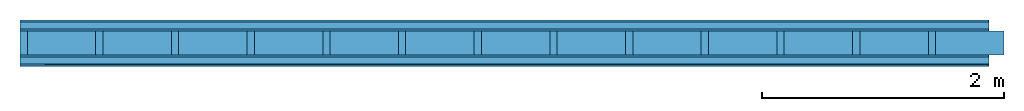
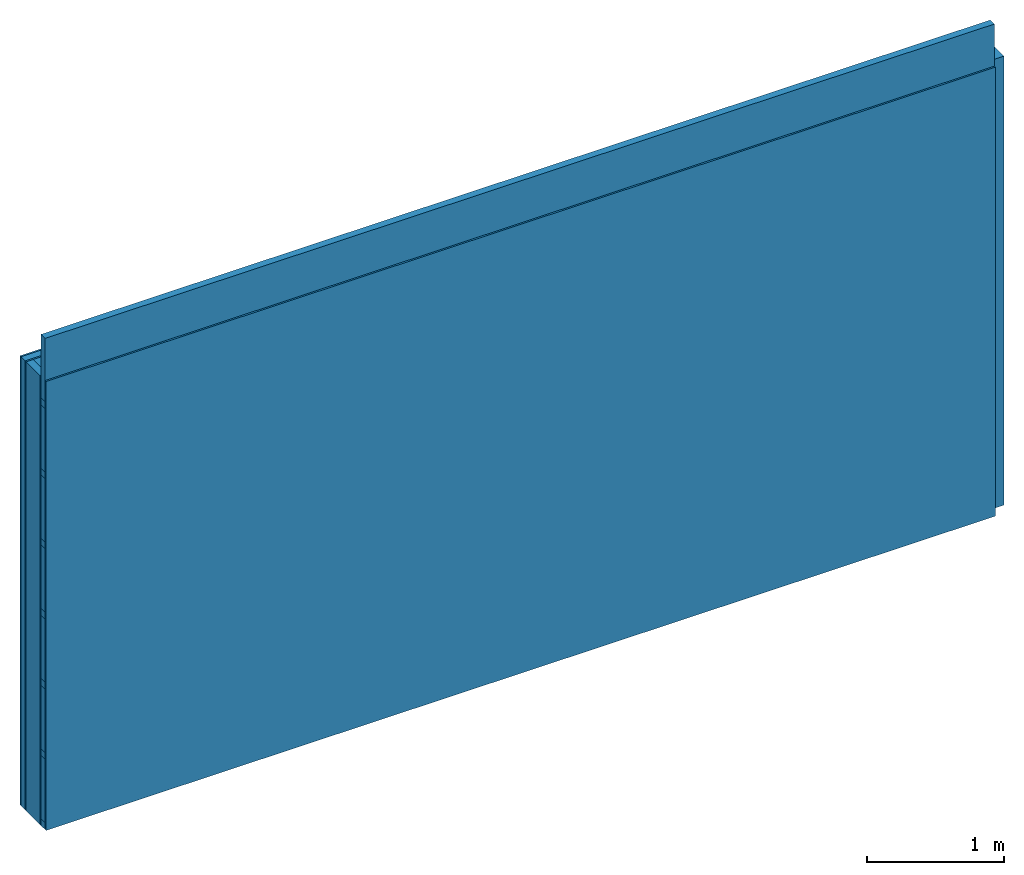
# One storey: 5 plates, 4 members, 1 element without a shape of its own.
"""IFC4 building model written with IfcOpenShell, lengths in metres."""

from ifc_helpers import new_model, si_unit, derived_unit, direction, frame, frame_2d, origin, origin_with_axes, place, context, project, spatial, rectangle, extrude, material, layer, layer_set, type_object, element, aggregate, save


model = new_model("IFC4")

# Units and contexts
plan_context = context("Plan", 3, precision=1e-05, world=origin(), true_north=direction((0.0, 1.0)))
model_context = context("Model", 3, precision=1e-05, world=origin(), true_north=direction((0.0, 1.0)))
ifc_project = project(units=[si_unit("LENGTHUNIT", "METRE"), derived_unit("SOUNDPRESSUREUNIT", [(si_unit("PRESSUREUNIT", "PASCAL", prefix="MICRO"), 0)]), si_unit("ENERGYUNIT", "JOULE", prefix="MEGA"), si_unit("MASSUNIT", "GRAM", prefix="KILO"), derived_unit("THERMALTRANSMITTANCEUNIT", [(si_unit("POWERUNIT", "WATT"), 1), (si_unit("AREAUNIT", "SQUARE_METRE"), -1), (si_unit("THERMODYNAMICTEMPERATUREUNIT", "KELVIN"), -1)]), derived_unit("AREADENSITYUNIT", [(si_unit("MASSUNIT", "GRAM", prefix="KILO"), 1), (si_unit("AREAUNIT", "SQUARE_METRE"), -1)]), derived_unit("USERDEFINED", [(si_unit("ENERGYUNIT", "JOULE", prefix="MEGA"), 1), (si_unit("AREAUNIT", "SQUARE_METRE"), -1)])], contexts=[plan_context, model_context])

# Site, building, storey
site = spatial("IfcSite", under=ifc_project)
building_placement = place(None, origin())
building = spatial("IfcBuilding", under=site, at=building_placement)
storey_placement = place(building_placement, origin())
storey = spatial("IfcBuildingStorey", under=building, at=storey_placement)

# Wall, members, plates
ifc_material_1 = material(Category="04.011")
ifc_layer_1 = layer(ifc_material_1, 0.015, Name="Surface 1")
ifc_material_2 = material(Category="10.008")
ifc_layer_2 = layer(ifc_material_2, 0.06, Name="outside 2nd layer")
ifc_material_3 = material(Category="03.007")
ifc_layer_3 = layer(ifc_material_3, 0.015, Name="outside 1st layer")
ifc_material_4 = material(Name="of the art")
ifc_layer_4 = layer(ifc_material_4, 0.0, Name="Bond")
ifc_layer_5 = layer(None, 0.2, Name="Support")
ifc_layer_6 = layer(ifc_material_4, 0.0, Name="Bond")
ifc_layer_7 = layer(ifc_material_3, 0.015, Name="1st layer")
ifc_layer_8 = layer(None, 0.06, Name="Battens / profiles")
ifc_layer_9 = layer(ifc_material_3, 0.015, Name="Covering 1st layer")
ifc_material_5 = material(Name="Glued joints")
ifc_layer_10 = layer(ifc_material_5, 0.0, Name="Surface")
ifc_layer_set = layer_set([ifc_layer_1, ifc_layer_2, ifc_layer_3, ifc_layer_4, ifc_layer_5, ifc_layer_6, ifc_layer_7, ifc_layer_8, ifc_layer_9, ifc_layer_10])
wall_type = type_object("IfcWallType", Name="D0601", PredefinedType="NOTDEFINED", material=ifc_layer_set)
wall_placement = place(None, frame((0.0, 0.0, 0.0), z_axis=(0.0, -1.0, 0.0), x_axis=(1.0, 0.0, 0.0)))
wall = element("IfcWall", 1, at=wall_placement, inside=storey, type_object=wall_type, material=ifc_layer_set, Name="Wall #1")
ifc_material_6 = material()
member_1_placement = place(wall_placement, origin())
member_1 = element("IfcMember", 2, at=member_1_placement, material=ifc_material_6, Name="Support", context=plan_context, shape_type="SweptSolid", body=[
    extrude(rectangle(XDim=0.06, YDim=0.2, at=frame_2d((0.03, 0.1), x_axis=(1.0, 0.0))), frame((0.0, 4.0, 0.09), z_axis=(0.0, -1.0, 0.0), x_axis=(1.0, 0.0, 0.0)), (0.0, 0.0, 1.0), 4.0),
    extrude(rectangle(XDim=0.06, YDim=0.2, at=frame_2d((0.03, 0.1), x_axis=(1.0, 0.0))), frame((0.625, 4.0, 0.09), z_axis=(0.0, -1.0, 0.0), x_axis=(1.0, 0.0, 0.0)), (0.0, 0.0, 1.0), 4.0),
    extrude(rectangle(XDim=0.06, YDim=0.2, at=frame_2d((0.03, 0.1), x_axis=(1.0, 0.0))), frame((1.25, 4.0, 0.09), z_axis=(0.0, -1.0, 0.0), x_axis=(1.0, 0.0, 0.0)), (0.0, 0.0, 1.0), 4.0),
    extrude(rectangle(XDim=0.06, YDim=0.2, at=frame_2d((0.03, 0.1), x_axis=(1.0, 0.0))), frame((1.875, 4.0, 0.09), z_axis=(0.0, -1.0, 0.0), x_axis=(1.0, 0.0, 0.0)), (0.0, 0.0, 1.0), 4.0),
    extrude(rectangle(XDim=0.06, YDim=0.2, at=frame_2d((0.03, 0.1), x_axis=(1.0, 0.0))), frame((2.5, 4.0, 0.09), z_axis=(0.0, -1.0, 0.0), x_axis=(1.0, 0.0, 0.0)), (0.0, 0.0, 1.0), 4.0),
    extrude(rectangle(XDim=0.06, YDim=0.2, at=frame_2d((0.03, 0.1), x_axis=(1.0, 0.0))), frame((3.125, 4.0, 0.09), z_axis=(0.0, -1.0, 0.0), x_axis=(1.0, 0.0, 0.0)), (0.0, 0.0, 1.0), 4.0),
    extrude(rectangle(XDim=0.06, YDim=0.2, at=frame_2d((0.03, 0.1), x_axis=(1.0, 0.0))), frame((3.75, 4.0, 0.09), z_axis=(0.0, -1.0, 0.0), x_axis=(1.0, 0.0, 0.0)), (0.0, 0.0, 1.0), 4.0),
    extrude(rectangle(XDim=0.06, YDim=0.2, at=frame_2d((0.03, 0.1), x_axis=(1.0, 0.0))), frame((4.375, 4.0, 0.09), z_axis=(0.0, -1.0, 0.0), x_axis=(1.0, 0.0, 0.0)), (0.0, 0.0, 1.0), 4.0),
    extrude(rectangle(XDim=0.06, YDim=0.2, at=frame_2d((0.03, 0.1), x_axis=(1.0, 0.0))), frame((5.0, 4.0, 0.09), z_axis=(0.0, -1.0, 0.0), x_axis=(1.0, 0.0, 0.0)), (0.0, 0.0, 1.0), 4.0),
    extrude(rectangle(XDim=0.06, YDim=0.2, at=frame_2d((0.03, 0.1), x_axis=(1.0, 0.0))), frame((5.625, 4.0, 0.09), z_axis=(0.0, -1.0, 0.0), x_axis=(1.0, 0.0, 0.0)), (0.0, 0.0, 1.0), 4.0),
    extrude(rectangle(XDim=0.06, YDim=0.2, at=frame_2d((0.03, 0.1), x_axis=(1.0, 0.0))), frame((6.25, 4.0, 0.09), z_axis=(0.0, -1.0, 0.0), x_axis=(1.0, 0.0, 0.0)), (0.0, 0.0, 1.0), 4.0),
    extrude(rectangle(XDim=0.06, YDim=0.2, at=frame_2d((0.03, 0.1), x_axis=(1.0, 0.0))), frame((6.875, 4.0, 0.09), z_axis=(0.0, -1.0, 0.0), x_axis=(1.0, 0.0, 0.0)), (0.0, 0.0, 1.0), 4.0),
    extrude(rectangle(XDim=0.06, YDim=0.2, at=frame_2d((0.03, 0.1), x_axis=(1.0, 0.0))), frame((7.5, 4.0, 0.09), z_axis=(0.0, -1.0, 0.0), x_axis=(1.0, 0.0, 0.0)), (0.0, 0.0, 1.0), 4.0),
])
ifc_material_7 = material()
member_2_placement = place(wall_placement, origin())
member_2 = element("IfcMember", 3, at=member_2_placement, material=ifc_material_7, Name="Cavity", context=plan_context, shape_type="SweptSolid", body=[
    extrude(rectangle(XDim=0.565, YDim=0.2, at=frame_2d((0.2825, 0.1), x_axis=(1.0, 0.0))), frame((0.06, 4.0, 0.09), z_axis=(0.0, -1.0, 0.0), x_axis=(1.0, 0.0, 0.0)), (0.0, 0.0, 1.0), 4.0),
    extrude(rectangle(XDim=0.565, YDim=0.2, at=frame_2d((0.2825, 0.1), x_axis=(1.0, 0.0))), frame((0.685, 4.0, 0.09), z_axis=(0.0, -1.0, 0.0), x_axis=(1.0, 0.0, 0.0)), (0.0, 0.0, 1.0), 4.0),
    extrude(rectangle(XDim=0.565, YDim=0.2, at=frame_2d((0.2825, 0.1), x_axis=(1.0, 0.0))), frame((1.31, 4.0, 0.09), z_axis=(0.0, -1.0, 0.0), x_axis=(1.0, 0.0, 0.0)), (0.0, 0.0, 1.0), 4.0),
    extrude(rectangle(XDim=0.565, YDim=0.2, at=frame_2d((0.2825, 0.1), x_axis=(1.0, 0.0))), frame((1.935, 4.0, 0.09), z_axis=(0.0, -1.0, 0.0), x_axis=(1.0, 0.0, 0.0)), (0.0, 0.0, 1.0), 4.0),
    extrude(rectangle(XDim=0.565, YDim=0.2, at=frame_2d((0.2825, 0.1), x_axis=(1.0, 0.0))), frame((2.56, 4.0, 0.09), z_axis=(0.0, -1.0, 0.0), x_axis=(1.0, 0.0, 0.0)), (0.0, 0.0, 1.0), 4.0),
    extrude(rectangle(XDim=0.565, YDim=0.2, at=frame_2d((0.2825, 0.1), x_axis=(1.0, 0.0))), frame((3.185, 4.0, 0.09), z_axis=(0.0, -1.0, 0.0), x_axis=(1.0, 0.0, 0.0)), (0.0, 0.0, 1.0), 4.0),
    extrude(rectangle(XDim=0.565, YDim=0.2, at=frame_2d((0.2825, 0.1), x_axis=(1.0, 0.0))), frame((3.81, 4.0, 0.09), z_axis=(0.0, -1.0, 0.0), x_axis=(1.0, 0.0, 0.0)), (0.0, 0.0, 1.0), 4.0),
    extrude(rectangle(XDim=0.565, YDim=0.2, at=frame_2d((0.2825, 0.1), x_axis=(1.0, 0.0))), frame((4.435, 4.0, 0.09), z_axis=(0.0, -1.0, 0.0), x_axis=(1.0, 0.0, 0.0)), (0.0, 0.0, 1.0), 4.0),
    extrude(rectangle(XDim=0.565, YDim=0.2, at=frame_2d((0.2825, 0.1), x_axis=(1.0, 0.0))), frame((5.06, 4.0, 0.09), z_axis=(0.0, -1.0, 0.0), x_axis=(1.0, 0.0, 0.0)), (0.0, 0.0, 1.0), 4.0),
    extrude(rectangle(XDim=0.565, YDim=0.2, at=frame_2d((0.2825, 0.1), x_axis=(1.0, 0.0))), frame((5.685, 4.0, 0.09), z_axis=(0.0, -1.0, 0.0), x_axis=(1.0, 0.0, 0.0)), (0.0, 0.0, 1.0), 4.0),
    extrude(rectangle(XDim=0.565, YDim=0.2, at=frame_2d((0.2825, 0.1), x_axis=(1.0, 0.0))), frame((6.31, 4.0, 0.09), z_axis=(0.0, -1.0, 0.0), x_axis=(1.0, 0.0, 0.0)), (0.0, 0.0, 1.0), 4.0),
    extrude(rectangle(XDim=0.565, YDim=0.2, at=frame_2d((0.2825, 0.1), x_axis=(1.0, 0.0))), frame((6.935, 4.0, 0.09), z_axis=(0.0, -1.0, 0.0), x_axis=(1.0, 0.0, 0.0)), (0.0, 0.0, 1.0), 4.0),
    extrude(rectangle(XDim=0.565, YDim=0.2, at=frame_2d((0.2825, 0.1), x_axis=(1.0, 0.0))), frame((7.56, 4.0, 0.09), z_axis=(0.0, -1.0, 0.0), x_axis=(1.0, 0.0, 0.0)), (0.0, 0.0, 1.0), 4.0),
])
ifc_material_8 = material()
member_3_placement = place(wall_placement, origin())
member_3 = element("IfcMember", 4, at=member_3_placement, material=ifc_material_8, Name="Battens / profiles", context=plan_context, shape_type="SweptSolid", body=[
    extrude(rectangle(XDim=0.06, YDim=0.06, at=frame_2d((0.03, 0.03), x_axis=(1.0, 0.0))), frame((0.0, 0.0, 0.305), z_axis=(1.0, 0.0, 0.0), x_axis=(0.0, 1.0, 0.0)), (0.0, 0.0, 1.0), 8.0),
    extrude(rectangle(XDim=0.06, YDim=0.06, at=frame_2d((0.03, 0.03), x_axis=(1.0, 0.0))), frame((0.0, 0.625, 0.305), z_axis=(1.0, 0.0, 0.0), x_axis=(0.0, 1.0, 0.0)), (0.0, 0.0, 1.0), 8.0),
    extrude(rectangle(XDim=0.06, YDim=0.06, at=frame_2d((0.03, 0.03), x_axis=(1.0, 0.0))), frame((0.0, 1.25, 0.305), z_axis=(1.0, 0.0, 0.0), x_axis=(0.0, 1.0, 0.0)), (0.0, 0.0, 1.0), 8.0),
    extrude(rectangle(XDim=0.06, YDim=0.06, at=frame_2d((0.03, 0.03), x_axis=(1.0, 0.0))), frame((0.0, 1.875, 0.305), z_axis=(1.0, 0.0, 0.0), x_axis=(0.0, 1.0, 0.0)), (0.0, 0.0, 1.0), 8.0),
    extrude(rectangle(XDim=0.06, YDim=0.06, at=frame_2d((0.03, 0.03), x_axis=(1.0, 0.0))), frame((0.0, 2.5, 0.305), z_axis=(1.0, 0.0, 0.0), x_axis=(0.0, 1.0, 0.0)), (0.0, 0.0, 1.0), 8.0),
    extrude(rectangle(XDim=0.06, YDim=0.06, at=frame_2d((0.03, 0.03), x_axis=(1.0, 0.0))), frame((0.0, 3.125, 0.305), z_axis=(1.0, 0.0, 0.0), x_axis=(0.0, 1.0, 0.0)), (0.0, 0.0, 1.0), 8.0),
    extrude(rectangle(XDim=0.06, YDim=0.06, at=frame_2d((0.03, 0.03), x_axis=(1.0, 0.0))), frame((0.0, 3.75, 0.305), z_axis=(1.0, 0.0, 0.0), x_axis=(0.0, 1.0, 0.0)), (0.0, 0.0, 1.0), 8.0),
])
member_4_placement = place(wall_placement, origin())
member_4 = element("IfcMember", 5, at=member_4_placement, material=ifc_material_7, Name="Cavity", context=plan_context, shape_type="SweptSolid", body=[
    extrude(rectangle(XDim=0.565, YDim=0.06, at=frame_2d((0.2825, 0.03), x_axis=(1.0, 0.0))), frame((0.0, 0.06, 0.305), z_axis=(1.0, 0.0, 0.0), x_axis=(0.0, 1.0, 0.0)), (0.0, 0.0, 1.0), 8.0),
    extrude(rectangle(XDim=0.565, YDim=0.06, at=frame_2d((0.2825, 0.03), x_axis=(1.0, 0.0))), frame((0.0, 0.685, 0.305), z_axis=(1.0, 0.0, 0.0), x_axis=(0.0, 1.0, 0.0)), (0.0, 0.0, 1.0), 8.0),
    extrude(rectangle(XDim=0.565, YDim=0.06, at=frame_2d((0.2825, 0.03), x_axis=(1.0, 0.0))), frame((0.0, 1.31, 0.305), z_axis=(1.0, 0.0, 0.0), x_axis=(0.0, 1.0, 0.0)), (0.0, 0.0, 1.0), 8.0),
    extrude(rectangle(XDim=0.565, YDim=0.06, at=frame_2d((0.2825, 0.03), x_axis=(1.0, 0.0))), frame((0.0, 1.935, 0.305), z_axis=(1.0, 0.0, 0.0), x_axis=(0.0, 1.0, 0.0)), (0.0, 0.0, 1.0), 8.0),
    extrude(rectangle(XDim=0.565, YDim=0.06, at=frame_2d((0.2825, 0.03), x_axis=(1.0, 0.0))), frame((0.0, 2.56, 0.305), z_axis=(1.0, 0.0, 0.0), x_axis=(0.0, 1.0, 0.0)), (0.0, 0.0, 1.0), 8.0),
    extrude(rectangle(XDim=0.565, YDim=0.06, at=frame_2d((0.2825, 0.03), x_axis=(1.0, 0.0))), frame((0.0, 3.185, 0.305), z_axis=(1.0, 0.0, 0.0), x_axis=(0.0, 1.0, 0.0)), (0.0, 0.0, 1.0), 8.0),
    extrude(rectangle(XDim=0.565, YDim=0.06, at=frame_2d((0.2825, 0.03), x_axis=(1.0, 0.0))), frame((0.0, 3.81, 0.305), z_axis=(1.0, 0.0, 0.0), x_axis=(0.0, 1.0, 0.0)), (0.0, 0.0, 1.0), 8.0),
])
plate_1_placement = place(wall_placement, origin())
plate_1 = element("IfcPlate", 6, at=plate_1_placement, material=ifc_material_1, Name="Surface 1", context=plan_context, shape_type="SweptSolid", body=[
    extrude(rectangle(XDim=8.0, YDim=4.0, at=frame_2d((4.0, 2.0), x_axis=(1.0, 0.0))), origin_with_axes(), (0.0, 0.0, 1.0), 0.015),
])
plate_2_placement = place(wall_placement, origin())
plate_2 = element("IfcPlate", 7, at=plate_2_placement, material=ifc_material_2, Name="outside 2nd layer", context=plan_context, shape_type="SweptSolid", body=[
    extrude(rectangle(XDim=8.0, YDim=4.0, at=frame_2d((4.0, 2.0), x_axis=(1.0, 0.0))), frame((0.0, 0.0, 0.015), z_axis=(0.0, 0.0, 1.0), x_axis=(1.0, 0.0, 0.0)), (0.0, 0.0, 1.0), 0.06),
])
plate_3_placement = place(wall_placement, origin())
plate_3 = element("IfcPlate", 8, at=plate_3_placement, material=ifc_material_3, Name="outside 1st layer", context=plan_context, shape_type="SweptSolid", body=[
    extrude(rectangle(XDim=8.0, YDim=4.0, at=frame_2d((4.0, 2.0), x_axis=(1.0, 0.0))), frame((0.0, 0.0, 0.075), z_axis=(0.0, 0.0, 1.0), x_axis=(1.0, 0.0, 0.0)), (0.0, 0.0, 1.0), 0.015),
])
plate_4_placement = place(wall_placement, origin())
plate_4 = element("IfcPlate", 9, at=plate_4_placement, material=ifc_material_3, Name="1st layer", context=plan_context, shape_type="SweptSolid", body=[
    extrude(rectangle(XDim=8.0, YDim=4.0, at=frame_2d((4.0, 2.0), x_axis=(1.0, 0.0))), frame((0.0, 0.0, 0.29), z_axis=(0.0, 0.0, 1.0), x_axis=(1.0, 0.0, 0.0)), (0.0, 0.0, 1.0), 0.015),
])
plate_5_placement = place(wall_placement, origin())
plate_5 = element("IfcPlate", 10, at=plate_5_placement, material=ifc_material_3, Name="Covering 1st layer", context=plan_context, shape_type="SweptSolid", body=[
    extrude(rectangle(XDim=8.0, YDim=4.0, at=frame_2d((4.0, 2.0), x_axis=(1.0, 0.0))), frame((0.0, 0.0, 0.365), z_axis=(0.0, 0.0, 1.0), x_axis=(1.0, 0.0, 0.0)), (0.0, 0.0, 1.0), 0.015),
])
aggregate(wall, [plate_1, plate_2, plate_3, member_1, member_2, plate_4, member_3, member_4, plate_5])

save(model, "model.ifc")
